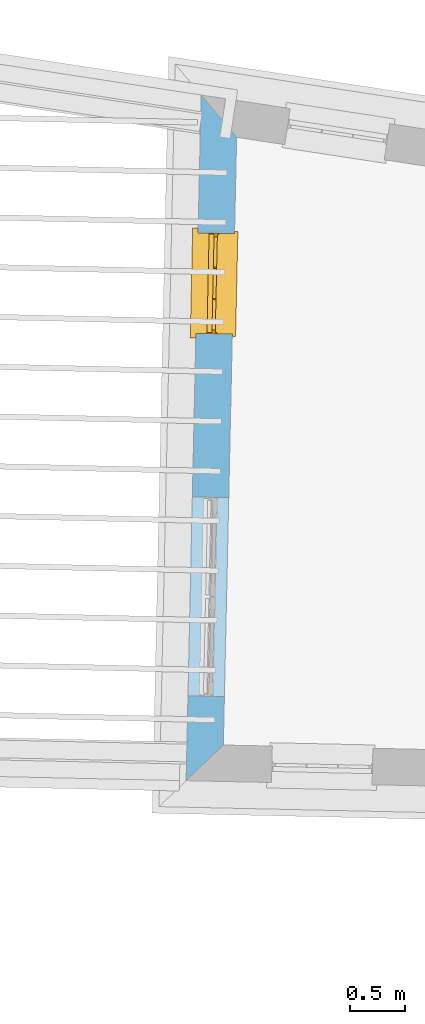
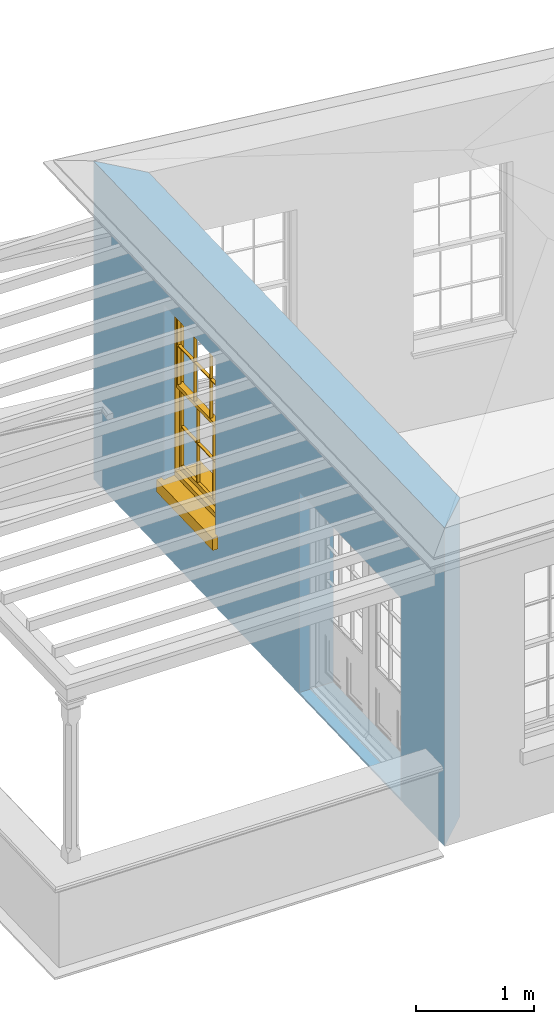
# One storey, part 3 of 12: 1 window, 2 openings, plus 1 element that does not belong to this part.
"""IFC2X3 building model written with IfcOpenShell, lengths in metres."""

from ifc_helpers import new_model, si_unit, frame, origin, place, context, subcontext, project, spatial, polyline, outline, extrude, faceted_brep, material, layer, layer_set, layer_usage, element, fill, save


model = new_model("IFC2X3")

# Units and contexts
model_context = context("Model", 3, world=origin())
body_context = subcontext(model_context, "Body", "Model", "MODEL_VIEW")
ifc_project = project(units=[si_unit("PLANEANGLEUNIT", "RADIAN"), si_unit("MASSUNIT", "GRAM", prefix="KILO"), si_unit("FORCEUNIT", "NEWTON", prefix="KILO"), si_unit("LENGTHUNIT", "METRE")], contexts=[model_context])

# Site, building, storey
site_placement = place(None, origin())
site = spatial("IfcSite", under=ifc_project, at=site_placement, CompositionType="ELEMENT")
building_placement = place(None, origin())
building = spatial("IfcBuilding", under=site, at=building_placement, Name="Building plot-18", CompositionType="ELEMENT")
storey_placement = place(None, frame((0.0, 0.0, 9.9)))
storey = spatial("IfcBuildingStorey", under=building, at=storey_placement, Name="Floor 2", CompositionType="ELEMENT", Elevation=9.9)

# Wall, openings, window
ifc_material = material(Name="Masonry")
ifc_layer = layer(ifc_material, 0.33, ventilated=False)
ifc_layer_set = layer_set([ifc_layer], Name="My Wall")
ifc_layer_usage = layer_usage(ifc_layer_set, "AXIS2", "NEGATIVE", 0.08)
wall_placement = place(storey_placement, origin())
wall = element("IfcWallStandardCase", 1, at=wall_placement, inside=storey, material=ifc_layer_usage, Name="exterior", context=body_context, shape_type="SweptSolid", body=[
    extrude(outline(polyline([(90.2260155594004, 26.2254654944291), (89.9043108567451, 26.6083343363116), (89.7686586524696, 20.406326207039), (90.1057958794453, 20.7290311654569), (90.2260155594004, 26.2254654944291)])), origin(), (0.0, 0.0, 1.0), 3.3),
])
opening_1_placement = place(storey_placement, frame((0.0, 0.0, 0.75)))
opening_1 = element("IfcOpeningElement", 2, at=opening_1_placement, cuts=wall, Name="Opening", ObjectType="Opening", context=body_context, shape_type="SweptSolid", body=[
    extrude(outline(polyline([(89.8770456128179, 25.3617695245838), (89.8571465758663, 24.451987117451), (90.1870676685628, 24.4447709831718), (90.2069667055144, 25.3545533903047), (89.8770456128179, 25.3617695245838)])), origin(), (0.0, 0.0, 1.0), 1.82),
])
opening_2_placement = place(storey_placement, frame((0.0, 0.0, 0.0199999999999996)))
element("IfcOpeningElement", 3, at=opening_2_placement, cuts=wall, Name="Opening", ObjectType="Opening", context=body_context, shape_type="SweptSolid", body=[
    extrude(outline(polyline([(89.8247960115718, 22.9729218577882), (89.7854352791401, 21.1733522612618), (90.1153563718366, 21.1661361269826), (90.1547171042684, 22.9657057235091), (89.8247960115718, 22.9729218577882)])), origin(), (0.0, 0.0, 1.0), 2.08),
])
window_placement = place(storey_placement, frame((90.1269858345577, 25.3563027561905, 0.75), z_axis=(0.0, 0.0, 1.0), x_axis=(-0.0198990369516139, -0.909782407132827, 0.0)))
window = element("IfcWindow", 4, at=window_placement, inside=storey, Name="living outside window", OverallHeight=1.82, OverallWidth=0.91, context=body_context, shape_type="Brep", held_by="IfcProductRepresentation", body=[
    faceted_brep([(0.033125, -0.105, 0.975209), (0.01, -0.105, 0.975209), (0.033125, -0.105, 1.376042), (0.876875, -0.105, 0.975209), (0.876875, -0.105, 1.376042), (0.9, -0.105, 0.975209), (0.876875, -0.105, 1.386042), (0.876875, -0.105, 1.786875), (0.9, -0.105, 1.81), (0.033125, -0.105, 1.786875), (0.033125, -0.105, 1.386042), (0.01, -0.105, 1.81), (0.876875, -0.135, 1.376042), (0.876875, -0.135, 0.975209), (0.9, -0.135, 0.937083), (0.033125, -0.135, 1.786875), (0.01, -0.135, 1.81), (0.033125, -0.135, 1.386042), (0.01, -0.135, 0.937083), (0.033125, -0.135, 0.975209), (0.033125, -0.135, 1.376042), (0.876875, -0.135, 1.786875), (0.876875, -0.135, 1.386042), (0.9, -0.135, 1.81), (0.033125, -0.105, 0.937083), (0.01, -0.105, 0.937083), (0.033125, -0.105, 0.53625), (0.876875, -0.105, 0.937083), (0.876875, -0.105, 0.53625), (0.9, -0.105, 0.937083), (0.876875, -0.105, 0.52625), (0.876875, -0.105, 0.125417), (0.9, -0.105, 0.077167), (0.033125, -0.105, 0.125417), (0.033125, -0.105, 0.52625), (0.01, -0.105, 0.077167), (-0.0425, -0.25, 0.01), (-0.0425, -0.3, 0.001667), (0.0, -0.25, 0.01), (0.9525, -0.25, 0.01), (0.91, -0.25, 0.01), (0.9525, -0.3, 0.001667), (-0.02, 0.08, 0.077167), (0.0, 0.08, 0.077167), (-0.02, 0.11, 0.077167), (0.0, -0.06, 0.077167), (0.01, -0.06, 0.077167), (0.91, -0.06, 0.077167), (0.91, 0.08, 0.077167), (0.9, -0.06, 0.077167), (0.93, 0.08, 0.077167), (0.93, 0.11, 0.077167), (0.01, -0.075, 0.975209), (0.9, -0.075, 0.975209), (0.876875, -0.075, 0.125417), (0.876875, -0.075, 0.52625), (0.9, -0.075, 0.077167), (0.876875, -0.075, 0.53625), (0.876875, -0.075, 0.937083), (0.033125, -0.075, 0.125417), (0.01, -0.075, 0.077167), (0.033125, -0.075, 0.52625), (0.033125, -0.075, 0.937083), (0.033125, -0.075, 0.53625), (-0.02, 0.08, 0.052167), (-0.02, 0.11, 0.052167), (0.93, 0.11, 0.052167), (0.93, 0.08, 0.052167), (0.91, 0.08, 0.052167), (0.0, 0.08, 0.052167), (0.91, -0.15, 0.026667), (0.0, -0.15, 0.026667), (-0.0425, -0.3, -0.123333), (0.9525, -0.3, -0.123333), (-0.0425, -0.25, -0.123333), (0.9525, -0.25, -0.123333), (0.01, -0.06, 1.81), (0.9, -0.06, 1.81), (0.0, -0.06, 1.82), (0.91, -0.06, 1.82), (0.01, -0.15, 0.077167), (0.9, -0.15, 0.077167), (0.592292, -0.105, 0.125417), (0.592292, -0.075, 0.125417), (0.317708, -0.075, 0.125417), (0.317708, -0.105, 0.125417), (0.592292, -0.105, 0.53625), (0.317708, -0.105, 0.53625), (0.317708, -0.105, 0.52625), (0.592292, -0.105, 0.52625), (0.592292, -0.075, 0.53625), (0.317708, -0.075, 0.53625), (0.592292, -0.135, 1.386042), (0.592292, -0.105, 1.386042), (0.317708, -0.105, 1.386042), (0.317708, -0.135, 1.386042), (0.317708, -0.135, 1.376042), (0.592292, -0.135, 1.376042), (0.317708, -0.105, 1.376042), (0.592292, -0.105, 1.376042), (0.602292, -0.135, 1.376042), (0.592292, -0.135, 0.975209), (0.602292, -0.135, 0.975209), (0.602292, -0.105, 0.975209), (0.592292, -0.105, 0.975209), (0.602292, -0.105, 1.376042), (0.602292, -0.075, 0.53625), (0.602292, -0.105, 0.53625), (0.317708, -0.075, 0.52625), (0.307708, -0.075, 0.125417), (0.307708, -0.075, 0.52625), (0.602292, -0.075, 0.52625), (0.602292, -0.075, 0.125417), (0.592292, -0.075, 0.52625), (0.307708, -0.075, 0.53625), (0.317708, -0.075, 0.937083), (0.307708, -0.075, 0.937083), (0.602292, -0.075, 0.937083), (0.592292, -0.075, 0.937083), (0.307708, -0.105, 0.52625), (0.307708, -0.105, 0.125417), (0.307708, -0.105, 0.53625), (0.307708, -0.105, 0.937083), (0.592292, -0.105, 0.937083), (0.317708, -0.105, 0.937083), (0.602292, -0.105, 0.937083), (0.602292, -0.105, 0.52625), (0.602292, -0.105, 0.125417), (0.307708, -0.135, 1.386042), (0.307708, -0.135, 1.376042), (0.307708, -0.135, 0.975209), (0.317708, -0.135, 0.975209), (0.317708, -0.135, 1.786875), (0.307708, -0.135, 1.786875), (0.602292, -0.135, 1.786875), (0.592292, -0.135, 1.786875), (0.602292, -0.135, 1.386042), (0.602292, -0.105, 1.386042), (0.307708, -0.105, 1.386042), (0.307708, -0.105, 1.786875), (0.317708, -0.105, 1.786875), (0.592292, -0.105, 1.786875), (0.602292, -0.105, 1.786875), (0.307708, -0.105, 1.376042), (0.317708, -0.105, 0.975209), (0.307708, -0.105, 0.975209), (0.91, -0.15, 1.82), (0.9, -0.15, 1.81), (0.01, -0.15, 1.81), (0.0, -0.15, 1.82), (0.91, -0.25, 0.0), (0.0, -0.25, 0.0), (0.91, 0.08, 0.0), (0.0, 0.08, 0.0)], [[[0, 1, 2]], [[3, 4, 5]], [[6, 7, 8]], [[9, 10, 11]], [[12, 13, 14]], [[15, 16, 17]], [[18, 19, 20]], [[21, 22, 23]], [[24, 25, 26]], [[27, 28, 29]], [[30, 31, 32]], [[33, 34, 35]], [[14, 27, 29]], [[25, 24, 18]], [[36, 37, 38]], [[39, 40, 41]], [[42, 43, 44]], [[45, 46, 43]], [[47, 48, 49]], [[50, 51, 48]], [[1, 0, 52]], [[5, 53, 3]], [[54, 55, 56]], [[57, 58, 53]], [[59, 60, 61]], [[62, 63, 52]], [[48, 43, 46, 49]], [[51, 44, 43, 48]], [[64, 42, 44, 65]], [[65, 44, 51, 66]], [[66, 51, 50, 67]], [[65, 66, 68, 69]], [[60, 56, 49, 46]], [[70, 71, 38, 40]], [[37, 41, 40, 38]], [[37, 72, 73, 41]], [[74, 75, 73, 72]], [[8, 11, 76, 77]], [[76, 78, 79, 77]], [[32, 35, 80, 81]], [[81, 80, 71, 70]], [[82, 83, 84, 85]], [[86, 87, 88, 89]], [[86, 90, 91, 87]], [[92, 93, 94, 95]], [[92, 95, 96, 97]], [[96, 98, 99, 97]], [[100, 97, 101, 102]], [[103, 104, 99, 105]], [[97, 99, 104, 101]], [[102, 103, 105, 100]], [[28, 57, 106, 107]], [[108, 84, 109, 110]], [[111, 112, 83, 113]], [[114, 110, 61, 63]], [[90, 113, 108, 91]], [[115, 91, 114, 116]], [[117, 106, 90, 118]], [[111, 106, 57, 55]], [[119, 110, 109, 120]], [[34, 61, 110, 119]], [[89, 113, 83, 82]], [[88, 108, 113, 89]], [[85, 84, 108, 88]], [[121, 114, 63, 26]], [[122, 116, 114, 121]], [[123, 118, 90, 86]], [[87, 91, 115, 124]], [[107, 106, 117, 125]], [[126, 111, 55, 30]], [[127, 112, 111, 126]], [[126, 30, 28, 107]], [[88, 119, 120, 85]], [[126, 89, 82, 127]], [[125, 123, 86, 107]], [[121, 26, 34, 119]], [[124, 122, 121, 87]], [[128, 17, 20, 129]], [[96, 129, 130, 131]], [[132, 133, 128, 95]], [[134, 135, 92, 136]], [[100, 12, 22, 136]], [[137, 6, 4, 105]], [[94, 138, 139, 140]], [[137, 93, 141, 142]], [[99, 98, 94, 93]], [[143, 2, 10, 138]], [[144, 145, 143, 98]], [[129, 143, 145, 130]], [[20, 2, 143, 129]], [[131, 144, 98, 96]], [[128, 138, 10, 17]], [[133, 139, 138, 128]], [[135, 141, 93, 92]], [[95, 94, 140, 132]], [[22, 6, 137, 136]], [[136, 137, 142, 134]], [[100, 105, 4, 12]], [[107, 86, 89, 126]], [[106, 111, 113, 90]], [[91, 108, 110, 114]], [[87, 121, 119, 88]], [[97, 100, 136, 92]], [[129, 96, 95, 128]], [[98, 143, 138, 94]], [[105, 99, 93, 137]], [[131, 101, 104, 144]], [[124, 115, 118, 123]], [[132, 140, 141, 135]], [[120, 109, 59, 33]], [[15, 9, 139, 133]], [[134, 142, 7, 21]], [[31, 54, 112, 127]], [[36, 74, 72, 37]], [[39, 41, 73, 75]], [[18, 14, 101, 131]], [[23, 16, 132, 135]], [[83, 56, 60, 84]], [[52, 53, 118, 115]], [[53, 52, 144, 104]], [[11, 8, 141, 140]], [[14, 18, 124, 123]], [[2, 1, 11, 10]], [[8, 5, 4, 6]], [[57, 53, 56, 55]], [[60, 52, 63, 61]], [[26, 25, 35, 34]], [[32, 29, 28, 30]], [[14, 23, 22, 12]], [[18, 20, 17, 16]], [[19, 0, 2, 20]], [[17, 10, 9, 15]], [[12, 4, 3, 13]], [[21, 7, 6, 22]], [[27, 58, 57, 28]], [[30, 55, 54, 31]], [[33, 59, 61, 34]], [[26, 63, 62, 24]], [[5, 8, 77, 53]], [[76, 11, 1, 52]], [[46, 45, 78, 76]], [[49, 77, 79, 47]], [[70, 146, 147, 81]], [[71, 80, 148, 149]], [[19, 130, 145, 0]], [[102, 13, 3, 103]], [[116, 122, 24, 62]], [[29, 32, 81, 14]], [[80, 35, 25, 18]], [[60, 46, 76, 52]], [[77, 49, 56, 53]], [[23, 14, 81, 147]], [[16, 148, 80, 18]], [[35, 85, 120]], [[120, 33, 35]], [[127, 82, 32]], [[32, 31, 127]], [[32, 82, 85, 35]], [[102, 101, 14]], [[14, 13, 102]], [[18, 131, 130]], [[130, 19, 18]], [[134, 21, 23]], [[23, 135, 134]], [[16, 15, 133]], [[133, 132, 16]], [[11, 140, 139]], [[139, 9, 11]], [[142, 141, 8]], [[8, 7, 142]], [[23, 147, 148, 16]], [[146, 149, 148, 147]], [[52, 115, 116]], [[116, 62, 52]], [[118, 53, 117]], [[58, 117, 53]], [[27, 125, 117, 58]], [[56, 83, 112]], [[112, 54, 56]], [[109, 84, 60]], [[60, 59, 109]], [[125, 27, 14]], [[14, 123, 125]], [[122, 124, 18]], [[18, 24, 122]], [[145, 144, 52]], [[52, 0, 145]], [[103, 3, 53]], [[53, 104, 103]], [[79, 78, 149, 146]], [[78, 45, 71, 149]], [[146, 70, 47, 79]], [[150, 75, 74, 151]], [[68, 66, 67]], [[48, 68, 67, 50]], [[69, 64, 65]], [[42, 64, 69, 43]], [[69, 68, 152, 153]], [[70, 68, 48, 47]], [[150, 152, 68, 70]], [[43, 69, 71, 45]], [[69, 153, 151, 71]], [[152, 150, 151, 153]], [[38, 151, 74, 36]], [[71, 151, 38]], [[39, 75, 150, 40]], [[40, 150, 70]]]),
])
fill(opening_1, window)

save(model, "model.ifc")
